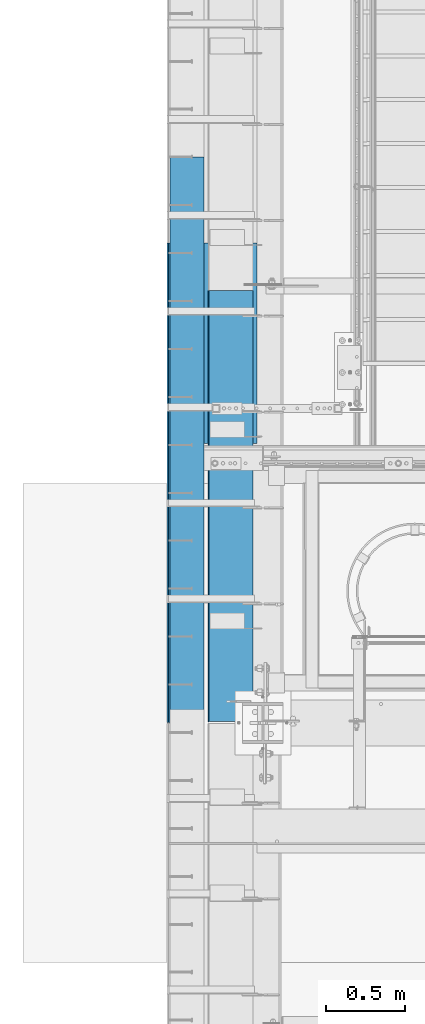
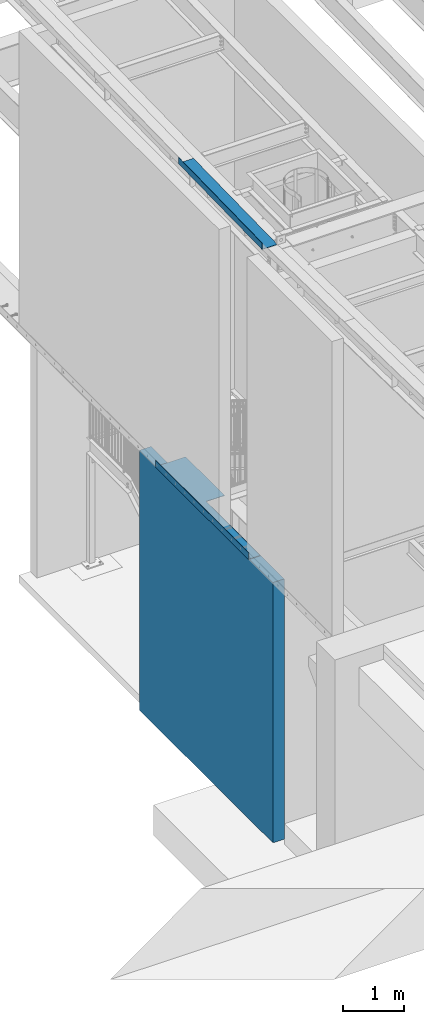
# One storey, part 1081 of 1763: 3 beams, 3 elements without a shape of their own.
"""IFC2X3 building model written with IfcOpenShell, lengths in millimetres."""

from ifc_helpers import new_model, si_unit, frame, origin_with_axes, place, context, subcontext, project, spatial, faceted_brep, material, type_object, element, aggregate, save


model = new_model("IFC2X3")

# Units and contexts
model_context = context("Model", 3, precision=1e-05, world=origin_with_axes())
body_context = subcontext(model_context, "Body", "Model", "MODEL_VIEW")
ifc_project = project(units=[si_unit("LENGTHUNIT", "METRE", prefix="MILLI"), si_unit("AREAUNIT", "SQUARE_METRE"), si_unit("VOLUMEUNIT", "CUBIC_METRE"), si_unit("MASSUNIT", "GRAM", prefix="KILO"), si_unit("TIMEUNIT", "SECOND"), si_unit("PLANEANGLEUNIT", "RADIAN"), si_unit("SOLIDANGLEUNIT", "STERADIAN"), si_unit("THERMODYNAMICTEMPERATUREUNIT", "DEGREE_CELSIUS"), si_unit("LUMINOUSINTENSITYUNIT", "LUMEN")], contexts=[model_context])

# Site, building, storey
site_placement = place(None, origin_with_axes())
site = spatial("IfcSite", under=ifc_project, at=site_placement, CompositionType="ELEMENT")
building_placement = place(site_placement, origin_with_axes())
building = spatial("IfcBuilding", under=site, at=building_placement, Name="Undefined", CompositionType="ELEMENT")
storey_placement = place(building_placement, origin_with_axes())
storey = spatial("IfcBuildingStorey", under=building, at=storey_placement, Name="Undefined", CompositionType="ELEMENT", Elevation=0.0)

# Assembly, beam
assembly_1_placement = place(storey_placement, origin_with_axes())
assembly_1 = element("IfcElementAssembly", 1, at=assembly_1_placement, inside=storey, Name="WALL", AssemblyPlace="NOTDEFINED", PredefinedType="REINFORCEMENT_UNIT")
ifc_material_1 = material(Name="CONCRETE/5000")
beam_type_1 = type_object("IfcBeamType", PredefinedType="NOTDEFINED")
beam_1_placement = place(assembly_1_placement, frame((-87858.0372736983, 29260.7999999971, 2597.15), z_axis=(-1.0, 0.0, 0.0), x_axis=(0.0, 1.0, 0.0)))
beam_1 = element("IfcBeam", 2, at=beam_1_placement, type_object=beam_type_1, material=ifc_material_1, Name="WALL", context=body_context, shape_type="Brep", body=[
    faceted_brep([(0.0, 2597.15, -107.949999999997), (0.0, 2597.15, 107.949999999997), (4359.27500610646, 2597.15, 107.949999999997), (4359.27500610646, 2597.15, -107.949999999997), (0.0, -2597.15, 107.949999999997), (4359.27500610646, -2597.15, 107.949999999997), (0.0, -2597.15, -107.949999999997), (4359.27500610646, -2597.15, -107.949999999997)], [[[0, 1, 2, 3]], [[1, 4, 5, 2]], [[4, 6, 7, 5]], [[6, 0, 3, 7]], [[5, 7, 3, 2]], [[6, 4, 1, 0]]]),
])
aggregate(assembly_1, [beam_1])

assembly_2_placement = place(storey_placement, origin_with_axes())
assembly_2 = element("IfcElementAssembly", 3, at=assembly_2_placement, inside=storey, Name="BEAM", AssemblyPlace="NOTDEFINED", PredefinedType="RIGID_FRAME")
ifc_material_2 = material(Name="STEEL/A36")
beam_type_2 = type_object("IfcBeamType", PredefinedType="NOTDEFINED")
beam_2_placement = place(assembly_2_placement, frame((-87413.5372736984, 31549.9755, 5199.0625), z_axis=(0.0, -1.0, 0.0), x_axis=(-1.0, 0.0, 0.0)))
beam_2 = element("IfcBeam", 4, at=beam_2_placement, type_object=beam_type_2, material=ifc_material_2, Name="BENT_PLATE", context=body_context, shape_type="Brep", body=[
    faceted_brep([(349.250012207034, -4.76249999999982, -250.824536132812), (349.250012207034, 4.76249999999982, -250.824536132812), (0.0, 4.76249999999982, -250.824536132812), (0.0, -4.76249999999982, -250.824536132812), (349.250012207034, -4.76249999999982, 1524.0), (349.250012207034, 4.76249999999982, 1524.0), (561.975000000006, -4.76249999999982, -1524.0), (0.0, -4.76249999999982, -1524.0), (0.0, 4.76249999999982, -1524.0), (571.5, 4.76249999999982, -1524.0), (571.5, -134.937496948242, -1524.0), (561.975000000006, -134.937496948242, -1524.0), (571.5, 4.76249999999982, 1524.0), (571.5, -134.937496948242, 1524.0), (561.975000000006, -134.937496948242, 1524.0), (561.975000000006, -4.76249999999982, 1524.0)], [[[0, 1, 2, 3]], [[4, 5, 1, 0]], [[6, 7, 8, 9, 10, 11]], [[9, 12, 13, 10]], [[14, 11, 10, 13]], [[15, 6, 11, 14]], [[3, 7, 6, 15, 4, 0]], [[8, 7, 3, 2]], [[12, 9, 8, 2, 1, 5]], [[15, 14, 13, 12, 5, 4]]]),
])
aggregate(assembly_2, [beam_2])

assembly_3_placement = place(storey_placement, origin_with_axes())
assembly_3 = element("IfcElementAssembly", 5, at=assembly_3_placement, inside=storey, Name="BEAM", AssemblyPlace="NOTDEFINED", PredefinedType="RIGID_FRAME")
beam_type_3 = type_object("IfcBeamType", PredefinedType="NOTDEFINED")
beam_3_placement = place(assembly_3_placement, frame((-87438.9372736983, 31402.1608083064, 11322.0141784357), z_axis=(0.0, -0.999786037781472, -0.0206852279954809), x_axis=(-1.0, 0.0, 0.0)))
beam_3 = element("IfcBeam", 6, at=beam_3_placement, type_object=beam_type_3, material=ifc_material_2, Name="BENT_PLATE", context=body_context, shape_type="Brep", body=[
    faceted_brep([(2.91038304567337e-11, -3.17499999963729, -1371.60000000396), (-2.91038304567337e-11, -3.17500000036489, 1371.60000000395), (-2.91038304567337e-11, 3.17499999963184, 1371.60000000395), (2.91038304567337e-11, 3.17500000035943, -1371.60000000396), (285.75000000016, 3.17499999930078, 1371.59999999897), (285.750000000276, 3.17499999982283, -1371.59999999897), (279.400000000271, -3.1750000001648, -1371.59999999897), (279.400000000154, -3.17500000068321, 1371.59999999897), (285.750000000218, -123.824997298658, 1371.59999999895), (285.750000000218, -123.824997298212, -1371.59999999898), (279.400000000212, -123.824997298658, 1371.59999999895), (279.400000000212, -123.824997298212, -1371.59999999898)], [[[0, 1, 2, 3]], [[3, 2, 4, 5]], [[1, 0, 6, 7]], [[5, 4, 8, 9]], [[4, 2, 1, 7, 10, 8]], [[7, 6, 11, 10]], [[6, 0, 3, 5, 9, 11]], [[10, 11, 9, 8]]]),
])
aggregate(assembly_3, [beam_3])

save(model, "model.ifc")
